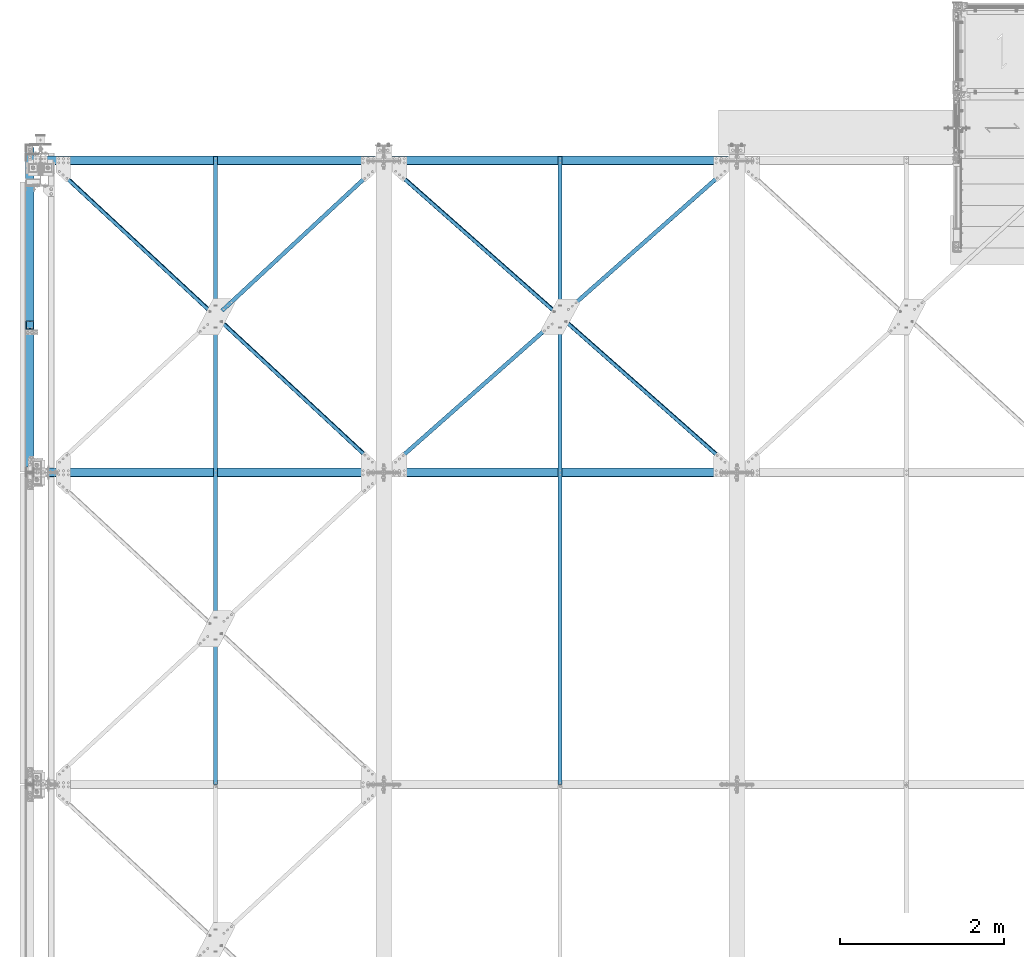
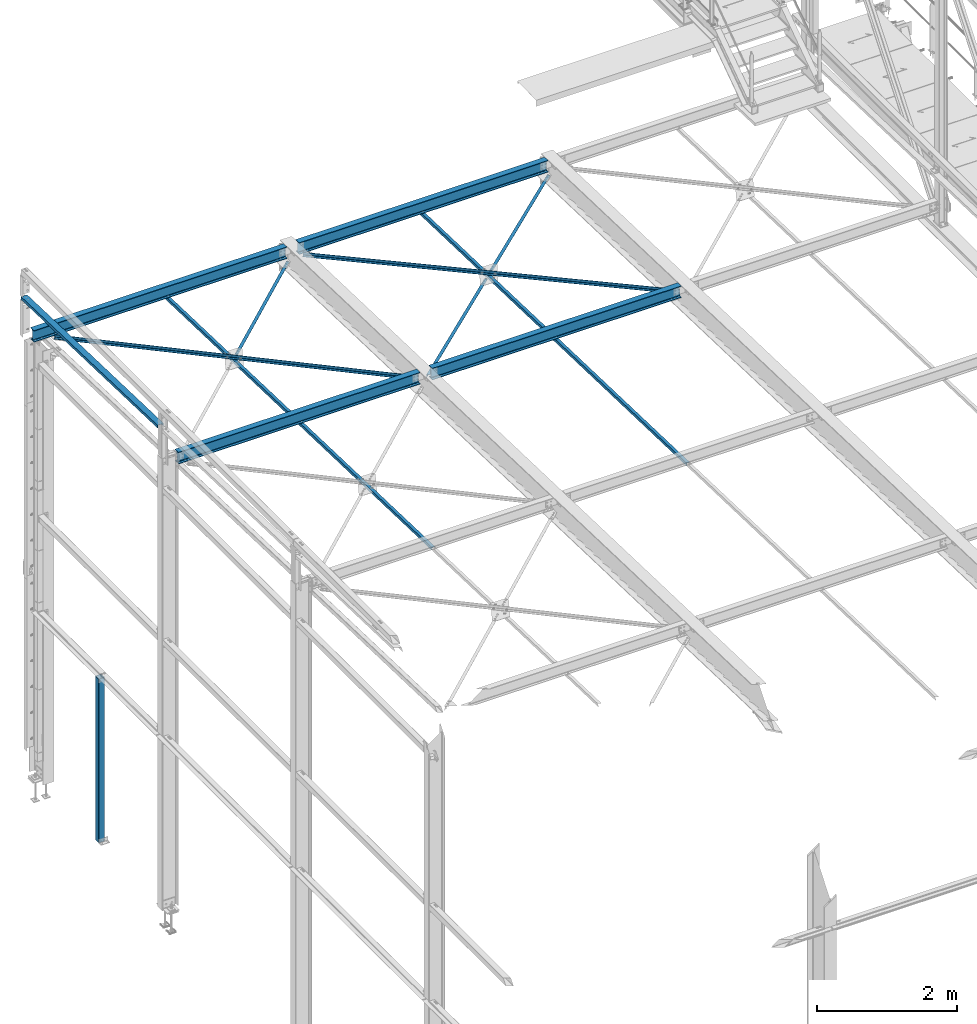
# One storey, part 44 of 496: 13 beams, 13 elements without a shape of their own.
"""IFC2X3 building model written with IfcOpenShell, lengths in millimetres."""

from ifc_helpers import new_model, si_unit, frame, origin_with_axes, origin_2d_with_axis, place, context, subcontext, project, spatial, hollow_rectangle, i_section, l_section, u_section, extrude, clip, halfspace, material, type_object, element, aggregate, save


model = new_model("IFC2X3")

# Units and contexts
model_context = context("Model", 3, precision=1e-05, world=origin_with_axes())
body_context = subcontext(model_context, "Body", "Model", "MODEL_VIEW")
ifc_project = project(units=[si_unit("LENGTHUNIT", "METRE", prefix="MILLI"), si_unit("AREAUNIT", "SQUARE_METRE"), si_unit("VOLUMEUNIT", "CUBIC_METRE"), si_unit("MASSUNIT", "GRAM", prefix="KILO"), si_unit("TIMEUNIT", "SECOND"), si_unit("PLANEANGLEUNIT", "RADIAN"), si_unit("SOLIDANGLEUNIT", "STERADIAN"), si_unit("THERMODYNAMICTEMPERATUREUNIT", "DEGREE_CELSIUS"), si_unit("LUMINOUSINTENSITYUNIT", "LUMEN")], contexts=[model_context])

# Site, building, storey
site_placement = place(None, origin_with_axes())
site = spatial("IfcSite", under=ifc_project, at=site_placement, CompositionType="ELEMENT")
building_placement = place(site_placement, origin_with_axes())
building = spatial("IfcBuilding", under=site, at=building_placement, Name="Undefined", CompositionType="ELEMENT")
storey_placement = place(building_placement, origin_with_axes())
storey = spatial("IfcBuildingStorey", under=building, at=storey_placement, Name="Undefined", CompositionType="ELEMENT", Elevation=0.0)

# Assembly, beam
assembly_1_placement = place(storey_placement, origin_with_axes())
assembly_1 = element("IfcElementAssembly", 1, at=assembly_1_placement, inside=storey, AssemblyPlace="NOTDEFINED", PredefinedType="NOTDEFINED")
ifc_material_1 = material(Name="Undefined/S235-E24")
beam_type_1 = type_object("IfcBeamType", PredefinedType="NOTDEFINED")
beam_1_placement = place(assembly_1_placement, frame((6328.01291896543, 13298.1323585649, 7400.97481652698), z_axis=(0.662381746075423, -0.748796805898184, 0.0235322319968), x_axis=(0.749166596217957, 0.662054810192613, -0.0208047930060529)))
beam_1 = element("IfcBeam", 2, at=beam_1_placement, type_object=beam_type_1, material=ifc_material_1, context=body_context, shape_type="Clipping", body=[
    clip(clip(extrude(l_section(Depth=50.0, Width=50.0, Thickness=5.0, FilletRadius=7.0, EdgeRadius=3.5, at=origin_2d_with_axis()), frame((2869.85557757118, -8.99537890086777e-13, -2.81529505720742e-12), z_axis=(-1.0, 0.0, 0.0), x_axis=(0.0, -1.0, 0.0)), (0.0, 0.0, 1.0), 2816.13), halfspace(frame((2704.84923675617, 25.0000247116786, 25.0000392269858), z_axis=(0.999999999998558, -1.69800000185205e-06, 0.0), x_axis=(-6.7626569939636e-10, 1.60677807515351e-06, -0.999999999998709)), False)), halfspace(frame((105.000008512056, 31.0011373895713, -25.0000000517266), z_axis=(-0.999999999997803, 2.09199999990344e-06, -1.31999999818056e-07), x_axis=(1.69800000215235e-06, 0.999999999998558, 0.0)), False)),
])
aggregate(assembly_1, [beam_1])

assembly_2_placement = place(storey_placement, origin_with_axes())
assembly_2 = element("IfcElementAssembly", 3, at=assembly_2_placement, inside=storey, AssemblyPlace="NOTDEFINED", PredefinedType="NOTDEFINED")
beam_2_placement = place(assembly_2_placement, frame((6327.00001266639, 7601.07123855934, 7586.01904275966), z_axis=(1.0, 0.0, 0.0), x_axis=(0.0, 0.999506556345274, -0.0314108870109058)))
beam_2 = element("IfcBeam", 4, at=beam_2_placement, type_object=beam_type_1, material=ifc_material_1, context=body_context, shape_type="SweptSolid", body=[
    extrude(l_section(Depth=50.0, Width=50.0, Thickness=5.0, FilletRadius=7.0, EdgeRadius=3.5, at=origin_2d_with_axis()), frame((7648.75199419146, 0.0, 0.0), z_axis=(-1.0, 0.0, 0.0), x_axis=(0.0, -1.0, 0.0)), (0.0, 0.0, 1.0), 7648.75),
])
aggregate(assembly_2, [beam_2])

assembly_3_placement = place(storey_placement, origin_with_axes())
assembly_3 = element("IfcElementAssembly", 5, at=assembly_3_placement, inside=storey, AssemblyPlace="NOTDEFINED", PredefinedType="NOTDEFINED")
beam_3_placement = place(assembly_3_placement, frame((2132.95747872314, 13298.0808843279, 7400.97343607126), z_axis=(0.680837487259443, -0.732073090297316, 0.0230066600093442), x_axis=(0.732434511694635, 0.680501526716288, -0.0213859349910859)))
beam_3 = element("IfcBeam", 6, at=beam_3_placement, type_object=beam_type_1, material=ifc_material_1, context=body_context, shape_type="Clipping", body=[
    clip(clip(extrude(l_section(Depth=50.0, Width=50.0, Thickness=5.0, FilletRadius=7.0, EdgeRadius=3.5, at=origin_2d_with_axis()), frame((2792.0585021269, 0.0, -9.94557782386253e-13), z_axis=(-1.0, 0.0, 0.0), x_axis=(0.0, -1.0, 0.0)), (0.0, 0.0, 1.0), 2736.72), halfspace(frame((2629.60191761616, 24.9946613142301, 24.996458746702), z_axis=(0.999999999999294, 3.87284877892096e-07, -1.12347404979193e-06), x_axis=(-1.44599998020567e-06, 0.0, -0.999999999998955)), False)), halfspace(frame((106.894615096866, 31.0043411251254, 25.0000010076456), z_axis=(1.0, 0.0, 0.0), x_axis=(0.0, 1.0, 0.0)), True)),
])
aggregate(assembly_3, [beam_3])

assembly_4_placement = place(storey_placement, origin_with_axes())
assembly_4 = element("IfcElementAssembly", 7, at=assembly_4_placement, inside=storey, AssemblyPlace="NOTDEFINED", PredefinedType="NOTDEFINED")
beam_4_placement = place(assembly_4_placement, frame((2132.00001266639, 7601.07123857222, 7586.01904275947), z_axis=(1.0, 0.0, 0.0), x_axis=(0.0, 0.999506556345274, -0.0314108870109058)))
beam_4 = element("IfcBeam", 8, at=beam_4_placement, type_object=beam_type_1, material=ifc_material_1, context=body_context, shape_type="SweptSolid", body=[
    extrude(l_section(Depth=50.0, Width=50.0, Thickness=5.0, FilletRadius=7.0, EdgeRadius=3.5, at=origin_2d_with_axis()), frame((7648.75199419146, 0.0, 0.0), z_axis=(-1.0, 0.0, 0.0), x_axis=(0.0, -1.0, 0.0)), (0.0, 0.0, 1.0), 7648.75),
])
aggregate(assembly_4, [beam_4])

assembly_5_placement = place(storey_placement, origin_with_axes())
assembly_5 = element("IfcElementAssembly", 9, at=assembly_5_placement, inside=storey, AssemblyPlace="NOTDEFINED", PredefinedType="NOTDEFINED")
beam_5_placement = place(assembly_5_placement, frame((4182.04254050677, 11399.8399519679, 7516.65952718173), z_axis=(-0.680837484653578, -0.732073079616414, 0.0230070769879449), x_axis=(-0.732434513155022, 0.680501525144028, -0.0213859350045245)))
beam_5 = element("IfcBeam", 10, at=beam_5_placement, type_object=beam_type_1, material=ifc_material_1, context=body_context, shape_type="Clipping", body=[
    clip(clip(extrude(l_section(Depth=50.0, Width=50.0, Thickness=5.0, FilletRadius=7.0, EdgeRadius=3.5, at=origin_2d_with_axis()), frame((5584.11699845502, 9.2886849947257e-13, 1.41670895678633e-13), z_axis=(-1.0, 0.0, 0.0), x_axis=(0.0, -1.0, 0.0)), (0.0, 0.0, 1.0), 5584.12), halfspace(frame((5421.65334739776, -24.9999835437211, -25.0000000106447), z_axis=(1.0, 0.0, 0.0), x_axis=(0.0, 0.0, 1.0)), False)), halfspace(frame((162.4631484794, 24.9999835444978, -24.9999999958345), z_axis=(-1.0, 0.0, 0.0), x_axis=(0.0, 0.0, 1.0)), False)),
])
aggregate(assembly_5, [beam_5])

assembly_6_placement = place(storey_placement, origin_with_axes())
assembly_6 = element("IfcElementAssembly", 11, at=assembly_6_placement, inside=storey, AssemblyPlace="NOTDEFINED", PredefinedType="NOTDEFINED")
beam_6_placement = place(assembly_6_placement, frame((4178.01288164492, 11398.1305794533, 7460.68157151343), z_axis=(0.662381746075423, -0.748796805898184, 0.0235322319968), x_axis=(0.749166596217957, 0.662054810192613, -0.0208047930060529)))
beam_6 = element("IfcBeam", 12, at=beam_6_placement, type_object=beam_type_1, material=ifc_material_1, context=body_context, shape_type="Clipping", body=[
    clip(clip(extrude(l_section(Depth=50.0, Width=50.0, Thickness=5.0, FilletRadius=7.0, EdgeRadius=3.5, at=origin_2d_with_axis()), frame((2816.1304739564, -9.192651170621e-13, -2.32658014073402e-13), z_axis=(-1.0, 0.0, 0.0), x_axis=(0.0, -1.0, 0.0)), (0.0, 0.0, 1.0), 2816.13), halfspace(frame((164.999927370294, -25.0001048205113, 24.9999605355824), z_axis=(-0.999999999998091, 1.45272125142988e-06, -1.3065366643919e-06), x_axis=(1.30653895757013e-06, 1.57853991639855e-06, -0.999999999997901)), False)), halfspace(frame((2764.85572224866, 31.0014349086723, -24.9999999868969), z_axis=(-0.999999999997803, 2.09199999990344e-06, -1.31999999818056e-07), x_axis=(1.69800000215235e-06, 0.999999999998558, 0.0)), True)),
])
aggregate(assembly_6, [beam_6])

assembly_7_placement = place(storey_placement, origin_with_axes())
assembly_7 = element("IfcElementAssembly", 13, at=assembly_7_placement, inside=storey, AssemblyPlace="NOTDEFINED", PredefinedType="NOTDEFINED")
beam_7_placement = place(assembly_7_placement, frame((8481.98714485529, 11399.889664645, 7516.65580191259), z_axis=(-0.662381618354144, -0.748796969224299, 0.0235306299756239), x_axis=(-0.749166598071848, 0.662054808063494, -0.0208047940019953)))
beam_7 = element("IfcBeam", 14, at=beam_7_placement, type_object=beam_type_1, material=ifc_material_1, context=body_context, shape_type="Clipping", body=[
    clip(clip(extrude(l_section(Depth=50.0, Width=50.0, Thickness=5.0, FilletRadius=7.0, EdgeRadius=3.5, at=origin_2d_with_axis()), frame((5739.71131316324, -9.29408325693476e-13, -2.03617236442933e-12), z_axis=(-1.0, 0.0, 0.0), x_axis=(0.0, -1.0, 0.0)), (0.0, 0.0, 1.0), 5739.71), halfspace(frame((5574.70497141151, -25.0000639070886, -25.0000000163691), z_axis=(0.999999999997803, 2.09200000135276e-06, 1.31999999817392e-07), x_axis=(0.0, 0.0, 1.0)), False)), halfspace(frame((164.999980996268, 25.0000653486823, -24.9999999946413), z_axis=(-0.99999999999782, -2.08799998896818e-06, 0.0), x_axis=(0.0, 0.0, 1.0)), False)),
])
aggregate(assembly_7, [beam_7])

assembly_8_placement = place(storey_placement, origin_with_axes())
assembly_8 = element("IfcElementAssembly", 15, at=assembly_8_placement, inside=storey, Name="LISSE", AssemblyPlace="NOTDEFINED", PredefinedType="NOTDEFINED")
beam_type_2 = type_object("IfcBeamType", PredefinedType="NOTDEFINED")
beam_8_placement = place(assembly_8_placement, frame((-129.999999987442, 11400.0000000009, 8171.98873515733), z_axis=(1.0, 0.0, 0.0), x_axis=(0.0, 0.999505396375583, -0.0314477760118172)))
beam_8 = element("IfcBeam", 16, at=beam_8_placement, type_object=beam_type_2, material=ifc_material_1, Name="LISSE", context=body_context, shape_type="Clipping", body=[
    clip(clip(extrude(u_section(Depth=100.0, FlangeWidth=50.0, WebThickness=4.0, FlangeThickness=4.0, at=origin_2d_with_axis()), frame((3963.54849814049, 2.75026425115877e-14, 0.0), z_axis=(-1.0, 0.0, 0.0), x_axis=(0.0, -1.0, 0.0)), (0.0, 0.0, 1.0), 3900.11), halfspace(frame((3958.90732059491, 97.0106538704367, 50.0000002001398), z_axis=(-0.999505396375582, -0.0314477760118219, 0.0), x_axis=(0.0, 0.0, 1.0)), True)), halfspace(frame((63.1124105854851, 61.0156037713568, 50.0000002001398), z_axis=(-0.999505396375582, -0.0314477760118219, 0.0), x_axis=(0.0, 0.0, 1.0)), False)),
])
aggregate(assembly_8, [beam_8])

assembly_9_placement = place(storey_placement, origin_with_axes())
assembly_9 = element("IfcElementAssembly", 17, at=assembly_9_placement, inside=storey, Name="MONTANT", AssemblyPlace="NOTDEFINED", PredefinedType="NOTDEFINED")
beam_type_3 = type_object("IfcBeamType", PredefinedType="NOTDEFINED")
beam_9_placement = place(assembly_9_placement, frame((-130.000011573673, 13195.0066102594, 2755.00000052336), z_axis=(1.0, 0.0, 0.0), x_axis=(0.0, 0.0, -1.0)))
beam_9 = element("IfcBeam", 18, at=beam_9_placement, type_object=beam_type_3, material=ifc_material_1, Name="MONTANT", context=body_context, shape_type="SweptSolid", body=[
    extrude(hollow_rectangle(XDim=100.0, YDim=100.0, WallThickness=4.0, InnerFilletRadius=4.0, OuterFilletRadius=8.0, at=origin_2d_with_axis()), frame((2850.00000064762, 0.0, 0.0), z_axis=(-1.0, 0.0, 0.0), x_axis=(0.0, -1.0, 0.0)), (0.0, 0.0, 1.0), 2850.0),
])
aggregate(assembly_9, [beam_9])

assembly_10_placement = place(storey_placement, origin_with_axes())
assembly_10 = element("IfcElementAssembly", 19, at=assembly_10_placement, inside=storey, AssemblyPlace="NOTDEFINED", PredefinedType="NOTDEFINED")
ifc_material_2 = material(Name="Undefined/S275-E28")
beam_type_4 = type_object("IfcBeamType", Name="IPE200", PredefinedType="NOTDEFINED")
beam_10_placement = place(assembly_10_placement, frame((4279.9999991887, 15199.9999999806, 7472.27130559969), z_axis=(0.0, 0.031410887010906, 0.999506556345274), x_axis=(1.0, 0.0, 0.0)))
beam_10 = element("IfcBeam", 20, at=beam_10_placement, type_object=beam_type_4, material=ifc_material_2, ObjectType="IPE200", context=body_context, shape_type="SweptSolid", body=[
    extrude(i_section(OverallWidth=100.0, OverallDepth=200.0, WebThickness=5.599999905, FlangeThickness=8.5, FilletRadius=12.0, at=origin_2d_with_axis()), frame((4100.0, 0.0, 0.0), z_axis=(-1.0, 0.0, 0.0), x_axis=(0.0, -1.0, 0.0)), (0.0, 0.0, 1.0), 4100.0),
])
aggregate(assembly_10, [beam_10])

assembly_11_placement = place(storey_placement, origin_with_axes())
assembly_11 = element("IfcElementAssembly", 21, at=assembly_11_placement, inside=storey, AssemblyPlace="NOTDEFINED", PredefinedType="NOTDEFINED")
beam_11_placement = place(assembly_11_placement, frame((4280.0, 11400.0005139275, 7591.68939134293), z_axis=(0.0, 0.031410887010906, 0.999506556345274), x_axis=(1.0, 0.0, 0.0)))
beam_11 = element("IfcBeam", 22, at=beam_11_placement, type_object=beam_type_4, material=ifc_material_2, ObjectType="IPE200", context=body_context, shape_type="SweptSolid", body=[
    extrude(i_section(OverallWidth=100.0, OverallDepth=200.0, WebThickness=5.599999905, FlangeThickness=8.5, FilletRadius=12.0, at=origin_2d_with_axis()), frame((4100.0, 0.0, 0.0), z_axis=(-1.0, 0.0, 0.0), x_axis=(0.0, -1.0, 0.0)), (0.0, 0.0, 1.0), 4100.0),
])
aggregate(assembly_11, [beam_11])

assembly_12_placement = place(storey_placement, origin_with_axes())
assembly_12 = element("IfcElementAssembly", 23, at=assembly_12_placement, inside=storey, AssemblyPlace="NOTDEFINED", PredefinedType="NOTDEFINED")
beam_12_placement = place(assembly_12_placement, frame((100.000000000018, 11400.0005139272, 7591.6893913429), z_axis=(0.0, 0.031410887010906, 0.999506556345274), x_axis=(1.0, 0.0, 0.0)))
beam_12 = element("IfcBeam", 24, at=beam_12_placement, type_object=beam_type_4, material=ifc_material_2, ObjectType="IPE200", context=body_context, shape_type="SweptSolid", body=[
    extrude(i_section(OverallWidth=100.0, OverallDepth=200.0, WebThickness=5.599999905, FlangeThickness=8.5, FilletRadius=12.0, at=origin_2d_with_axis()), frame((3980.00000000009, 0.0, 0.0), z_axis=(-1.0, 0.0, 0.0), x_axis=(0.0, -1.0, 0.0)), (0.0, 0.0, 1.0), 3980.0),
])
aggregate(assembly_12, [beam_12])

assembly_13_placement = place(storey_placement, origin_with_axes())
assembly_13 = element("IfcElementAssembly", 25, at=assembly_13_placement, inside=storey, AssemblyPlace="NOTDEFINED", PredefinedType="NOTDEFINED")
beam_13_placement = place(assembly_13_placement, frame((-85.0000008112765, 15199.9999999806, 7472.27130559969), z_axis=(0.0, 0.031410887010906, 0.999506556345274), x_axis=(1.0, 0.0, 0.0)))
beam_13 = element("IfcBeam", 26, at=beam_13_placement, type_object=beam_type_4, material=ifc_material_2, ObjectType="IPE200", context=body_context, shape_type="SweptSolid", body=[
    extrude(i_section(OverallWidth=100.0, OverallDepth=200.0, WebThickness=5.599999905, FlangeThickness=8.5, FilletRadius=12.0, at=origin_2d_with_axis()), frame((4164.99999999998, 0.0, 0.0), z_axis=(-1.0, 0.0, 0.0), x_axis=(0.0, -1.0, 0.0)), (0.0, 0.0, 1.0), 4165.0),
])
aggregate(assembly_13, [beam_13])

save(model, "model.ifc")
